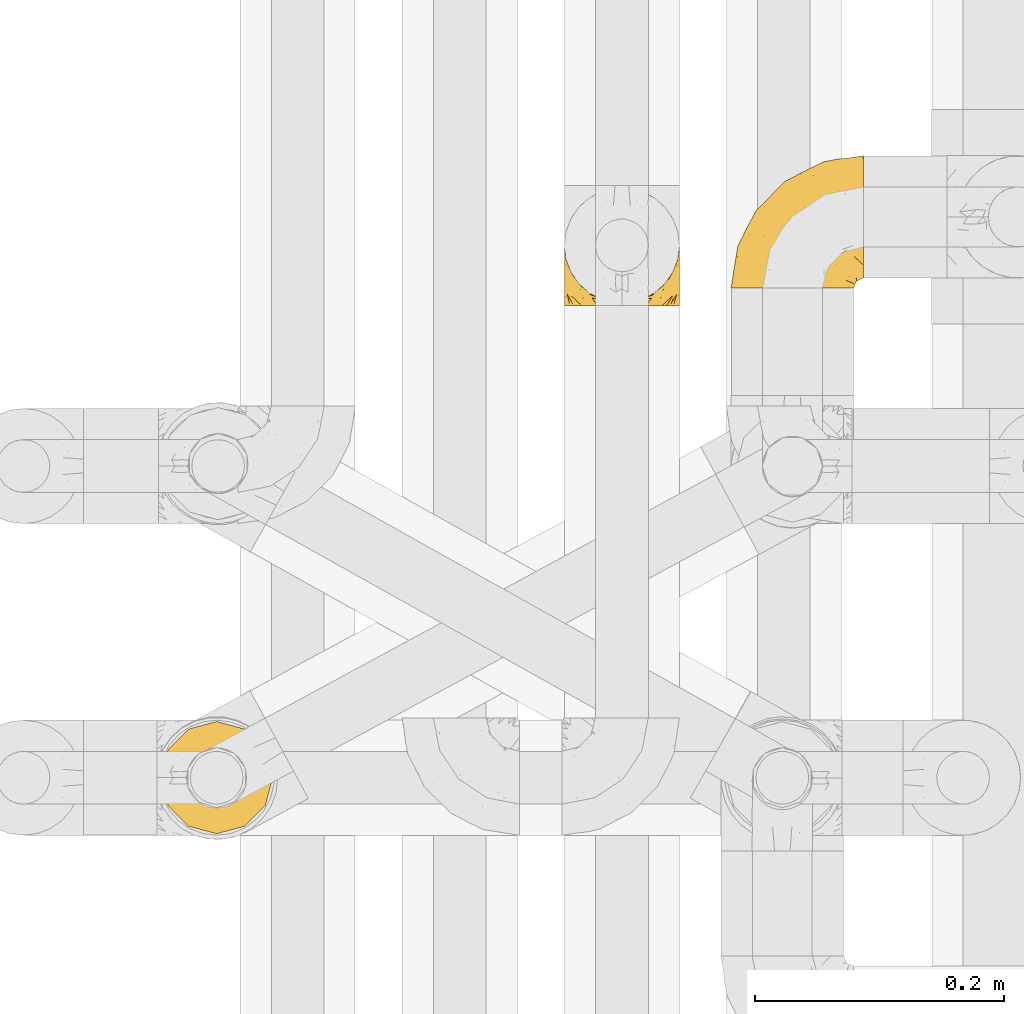
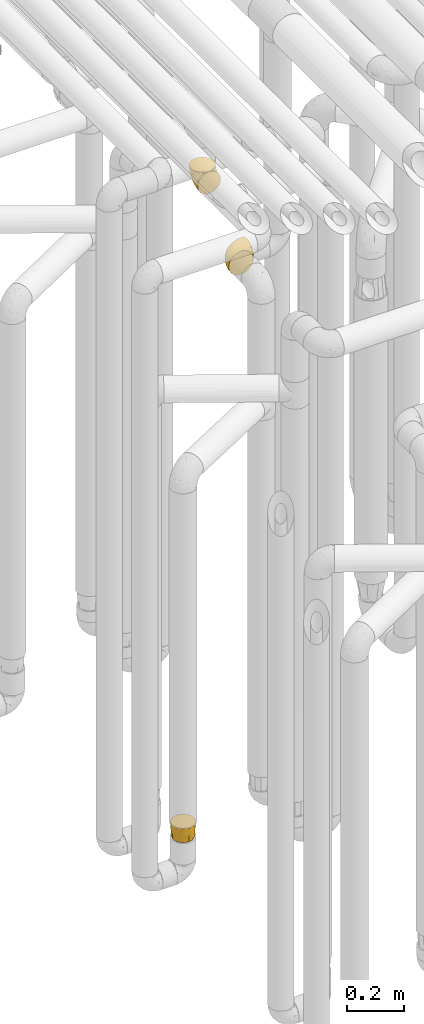
# One storey, part 160 of 827: 3 coverings.
"""IFC2X3 building model written with IfcOpenShell, lengths in millimetres."""

from ifc_helpers import new_model, entity, si_unit, converted_unit, derived_unit, direction, frame, origin, place, context, subcontext, project, spatial, faceted_brep, element, save


model = new_model("IFC2X3")

# Units and contexts
model_context = context("Model", 3, precision=0.01, world=origin(), true_north=direction((6.12303176911189e-17, 1.0)))
body_context = subcontext(model_context, "Body", "Model", "MODEL_VIEW")
ifc_project = project(units=[si_unit("LENGTHUNIT", "METRE", prefix="MILLI"), si_unit("AREAUNIT", "SQUARE_METRE"), si_unit("VOLUMEUNIT", "CUBIC_METRE"), converted_unit("PLANEANGLEUNIT", "DEGREE", entity("IfcRatioMeasure", 0.0174532925199433), si_unit("PLANEANGLEUNIT", "RADIAN"), dimensions=[0, 0, 0, 0, 0, 0, 0]), si_unit("MASSUNIT", "GRAM", prefix="KILO"), derived_unit("MASSDENSITYUNIT", [(si_unit("MASSUNIT", "GRAM", prefix="KILO"), 1), (si_unit("LENGTHUNIT", "METRE"), -3)]), derived_unit("MOMENTOFINERTIAUNIT", [(si_unit("LENGTHUNIT", "METRE"), 4)]), si_unit("TIMEUNIT", "SECOND"), si_unit("FREQUENCYUNIT", "HERTZ"), si_unit("THERMODYNAMICTEMPERATUREUNIT", "DEGREE_CELSIUS"), derived_unit("THERMALTRANSMITTANCEUNIT", [(si_unit("MASSUNIT", "GRAM", prefix="KILO"), 1), (si_unit("THERMODYNAMICTEMPERATUREUNIT", "KELVIN"), -1), (si_unit("TIMEUNIT", "SECOND"), -3)]), derived_unit("VOLUMETRICFLOWRATEUNIT", [(si_unit("LENGTHUNIT", "METRE"), 3), (si_unit("TIMEUNIT", "SECOND"), -1)]), derived_unit("MASSFLOWRATEUNIT", [(si_unit("MASSUNIT", "GRAM", prefix="KILO"), 1), (si_unit("TIMEUNIT", "SECOND"), -1)]), derived_unit("ROTATIONALFREQUENCYUNIT", [(si_unit("TIMEUNIT", "SECOND"), -1)]), si_unit("ELECTRICCURRENTUNIT", "AMPERE"), si_unit("ELECTRICVOLTAGEUNIT", "VOLT"), si_unit("POWERUNIT", "WATT"), si_unit("FORCEUNIT", "NEWTON", prefix="KILO"), si_unit("ILLUMINANCEUNIT", "LUX"), si_unit("LUMINOUSFLUXUNIT", "LUMEN"), si_unit("LUMINOUSINTENSITYUNIT", "CANDELA"), derived_unit("USERDEFINED", [(si_unit("MASSUNIT", "GRAM", prefix="KILO"), -1), (si_unit("LENGTHUNIT", "METRE"), -2), (si_unit("TIMEUNIT", "SECOND"), 3), (si_unit("LUMINOUSFLUXUNIT", "LUMEN"), 1)]), derived_unit("LINEARVELOCITYUNIT", [(si_unit("LENGTHUNIT", "METRE"), 1), (si_unit("TIMEUNIT", "SECOND"), -1)]), si_unit("PRESSUREUNIT", "PASCAL"), derived_unit("USERDEFINED", [(si_unit("LENGTHUNIT", "METRE"), -2), (si_unit("MASSUNIT", "GRAM", prefix="KILO"), 1), (si_unit("TIMEUNIT", "SECOND"), -2)]), derived_unit("LINEARFORCEUNIT", [(si_unit("MASSUNIT", "GRAM", prefix="KILO"), 1), (si_unit("LENGTHUNIT", "METRE"), 1), (si_unit("TIMEUNIT", "SECOND"), -2), (si_unit("LENGTHUNIT", "METRE"), -1)]), derived_unit("PLANARFORCEUNIT", [(si_unit("MASSUNIT", "GRAM", prefix="KILO"), 1), (si_unit("LENGTHUNIT", "METRE"), 1), (si_unit("TIMEUNIT", "SECOND"), -2), (si_unit("LENGTHUNIT", "METRE"), -2)])], contexts=[model_context])

# Site, building, storey
site_placement = place(None, origin())
site = spatial("IfcSite", under=ifc_project, at=site_placement, CompositionType="ELEMENT")
building_placement = place(site_placement, origin())
building = spatial("IfcBuilding", under=site, at=building_placement, CompositionType="ELEMENT")
storey_placement = place(building_placement, frame((0.0, 0.0, 28200.0)))
storey = spatial("IfcBuildingStorey", under=building, at=storey_placement, Name="08", CompositionType="ELEMENT", Elevation=28200.0)

# Coverings
covering_1_placement = place(storey_placement, frame((35686.11, 11947.49, 2549.25)))
element("IfcCovering", 1, at=covering_1_placement, inside=storey, Name=":ADSK_", ObjectType=":ADSK_", PredefinedType="INSULATION", context=body_context, shape_type="Brep", body=[
    faceted_brep([(50.75, 1.6, 99.9), (39.8, 1.6, 98.66), (29.41, 1.6, 95.02), (20.09, 1.6, 89.17), (12.31, 1.6, 81.38), (6.46, 1.6, 72.06), (2.83, 1.6, 61.68), (1.6, 1.6, 50.75), (2.83, 1.6, 39.8), (6.47, 1.6, 29.41), (12.32, 1.6, 20.09), (20.11, 1.6, 12.31), (29.43, 1.6, 6.46), (39.81, 1.6, 2.83), (50.75, 1.6, 1.6), (56.45, 1.6, 2.24), (61.69, 1.6, 2.83), (66.88, 1.6, 4.65), (72.08, 1.6, 6.47), (81.4, 1.6, 12.32), (89.18, 1.6, 20.11), (95.03, 1.6, 29.43), (98.66, 1.6, 39.81), (99.9, 1.6, 50.75), (98.66, 1.6, 61.69), (95.02, 1.6, 72.08), (89.17, 1.6, 81.4), (81.38, 1.6, 89.18), (72.06, 1.6, 95.03), (66.87, 1.6, 96.85), (61.68, 1.6, 98.66), (56.45, 1.6, 99.25), (53.6, 1.6, 99.57), (107.75, 11.12, 38.02), (107.75, 16.03, 26.17), (107.75, 19.94, 21.08), (107.75, 23.84, 15.99), (107.75, 28.93, 12.09), (107.75, 34.02, 8.18), (107.75, 39.95, 5.73), (107.75, 45.87, 3.27), (107.75, 52.86, 2.35), (107.75, 55.73, 1.97), (107.75, 58.6, 1.6), (107.75, 71.32, 3.27), (107.75, 83.17, 8.18), (107.75, 93.35, 15.99), (107.75, 101.16, 26.17), (107.75, 106.07, 38.02), (107.75, 107.75, 50.75), (107.75, 106.07, 63.47), (107.75, 101.16, 75.32), (107.75, 93.35, 85.5), (107.75, 83.17, 93.31), (107.75, 71.32, 98.22), (107.75, 58.6, 99.9), (107.75, 52.86, 99.14), (107.75, 45.87, 98.22), (107.75, 39.95, 95.77), (107.75, 34.02, 93.31), (107.75, 28.93, 89.4), (107.75, 23.84, 85.5), (107.75, 19.94, 80.41), (107.75, 16.03, 75.32), (107.75, 11.12, 63.47), (107.75, 9.45, 50.75), (39.38, 81.82, 59.31), (49.75, 84.02, 73.08), (57.38, 93.05, 63.72), (74.94, 102.55, 50.75), (85.97, 104.83, 58.64), (95.66, 105.83, 50.75), (67.82, 91.87, 76.74), (83.09, 101.74, 67.68), (89.16, 97.07, 78.92), (37.01, 38.45, 94.31), (43.46, 22.17, 98.76), (51.79, 42.04, 98.4), (85.58, 77.69, 94.57), (62.84, 75.76, 89.91), (62.77, 62.11, 96.32), (88.17, 66.08, 98.79), (85.93, 54.26, 99.9), (91.42, 55.35, 99.9), (96.91, 56.44, 99.9), (99.62, 56.98, 99.9), (102.33, 57.52, 99.9), (82.57, 87.84, 87.31), (32.75, 19.41, 95.61), (13.79, 48.89, 60.43), (6.77, 26.34, 65.24), (16.46, 44.55, 72.87), (55.08, 23.41, 99.9), (58.17, 28.03, 99.9), (61.26, 32.65, 99.9), (64.35, 37.28, 99.9), (67.44, 41.9, 99.9), (24.18, 20.6, 90.65), (23.37, 63.36, 63.14), (49.76, 62.21, 91.89), (9.84, 19.94, 75.25), (3.51, 13.68, 50.75), (55.75, 80.85, 82.18), (42.34, 66.53, 85.08), (37.78, 71.06, 76.93), (21.87, 63.99, 50.75), (33.61, 75.73, 50.75), (17.1, 26.77, 83.02), (51.28, 4.31, 99.9), (51.82, 7.01, 99.9), (52.9, 12.43, 99.9), (53.99, 17.92, 99.9), (28.01, 43.43, 87.13), (28.99, 56.23, 80.85), (69.9, 54.97, 99.17), (6.79, 34.4, 50.75), (72.06, 44.99, 99.9), (76.69, 48.08, 99.9), (81.31, 51.17, 99.9), (45.35, 87.47, 50.75), (34.79, 74.55, 67.61), (25.72, 60.86, 72.25), (14.33, 49.19, 50.75), (60.15, 95.01, 50.75), (62.38, 10.27, 98.69), (100.57, 48.79, 99.01), (91.06, 45.16, 98.79), (97.66, 44.99, 98.29), (97.55, 6.17, 68.51), (93.65, 7.65, 76.82), (66.85, 21.59, 98.54), (61.93, 19.96, 99.3), (101.4, 21.0, 83.57), (100.07, 27.2, 89.47), (101.36, 14.83, 75.76), (95.94, 19.7, 84.86), (96.3, 10.93, 75.89), (101.98, 9.63, 64.77), (85.88, 19.97, 90.83), (78.88, 21.13, 94.62), (82.8, 14.14, 90.37), (102.58, 30.2, 91.18), (82.88, 8.12, 88.65), (88.57, 9.93, 84.11), (88.67, 24.62, 91.75), (69.08, 11.87, 96.86), (102.19, 7.15, 50.75), (100.06, 5.32, 58.97), (70.56, 26.68, 98.37), (91.07, 13.92, 83.91), (77.56, 30.67, 97.52), (96.59, 36.65, 95.55), (86.38, 42.89, 98.76), (91.79, 34.04, 95.26), (81.71, 36.6, 98.04), (94.11, 26.41, 90.65), (76.09, 10.07, 93.51), (76.91, 15.83, 94.16), (81.44, 41.99, 99.1), (101.37, 14.83, 25.73), (94.12, 26.4, 10.84), (101.41, 21.01, 17.92), (95.96, 19.71, 16.64), (96.22, 5.72, 30.44), (66.85, 21.6, 2.95), (61.94, 19.96, 2.19), (58.17, 28.03, 1.6), (69.1, 11.87, 4.63), (88.58, 9.93, 17.39), (96.91, 56.44, 1.6), (102.33, 57.52, 1.6), (105.04, 58.06, 1.6), (82.9, 8.13, 12.86), (82.82, 14.15, 11.13), (97.66, 44.99, 3.2), (96.59, 36.65, 5.94), (100.07, 27.21, 12.02), (91.79, 34.04, 6.23), (102.58, 30.2, 10.31), (76.13, 10.06, 8.0), (76.93, 15.83, 7.34), (100.57, 48.79, 2.48), (86.38, 42.89, 2.73), (90.86, 45.38, 2.64), (52.9, 12.43, 1.6), (62.39, 10.28, 2.8), (101.98, 9.64, 36.71), (91.42, 55.35, 1.6), (85.93, 54.26, 1.6), (99.49, 6.05, 38.59), (51.82, 7.01, 1.6), (52.36, 9.72, 1.6), (61.26, 32.65, 1.6), (70.56, 26.68, 3.12), (91.09, 13.92, 17.59), (64.35, 37.28, 1.6), (77.6, 30.66, 3.98), (78.89, 21.14, 6.87), (81.71, 36.59, 3.45), (88.69, 24.6, 9.76), (53.99, 17.92, 1.6), (55.08, 23.41, 1.6), (96.31, 10.93, 25.62), (85.9, 19.97, 10.67), (81.45, 41.99, 2.39), (76.69, 48.08, 1.6), (81.31, 51.17, 1.6), (72.06, 44.99, 1.6), (67.44, 41.9, 1.6), (69.6, 55.26, 2.4), (85.97, 104.83, 42.85), (82.57, 87.84, 14.18), (63.16, 75.91, 11.56), (55.81, 80.84, 19.27), (67.81, 91.87, 24.75), (49.73, 83.98, 28.37), (32.55, 19.16, 5.95), (43.23, 22.37, 2.79), (88.17, 66.08, 2.71), (57.38, 93.05, 37.78), (83.08, 101.74, 33.81), (89.16, 97.07, 22.57), (85.58, 77.69, 6.92), (16.46, 44.55, 28.61), (6.77, 26.34, 36.24), (13.8, 48.9, 41.05), (37.71, 70.99, 24.55), (34.8, 74.55, 33.88), (36.83, 37.8, 7.11), (39.38, 81.82, 42.18), (17.12, 26.77, 18.46), (24.19, 20.6, 10.84), (28.89, 56.15, 20.69), (25.69, 60.85, 29.27), (51.77, 42.06, 3.1), (45.66, 57.03, 9.18), (23.39, 63.4, 38.38), (9.85, 19.94, 26.23), (28.11, 43.59, 14.34), (62.27, 62.61, 5.46), (42.35, 66.52, 16.39)], [[[0, 1, 2, 3, 4, 5, 6, 7, 8, 9, 10, 11, 12, 13, 14, 15, 16, 17, 18, 19, 20, 21, 22, 23, 24, 25, 26, 27, 28, 29, 30, 31, 32]], [[33, 34, 35, 36, 37, 38, 39, 40, 41, 42, 43, 44, 45, 46, 47, 48, 49, 50, 51, 52, 53, 54, 55, 56, 57, 58, 59, 60, 61, 62, 63, 64, 65]], [[66, 67, 68]], [[69, 70, 71]], [[68, 72, 73]], [[73, 72, 74]], [[75, 76, 77]], [[78, 79, 80]], [[51, 50, 73]], [[81, 82, 83, 84, 85, 86, 55]], [[52, 87, 53]], [[74, 52, 51]], [[2, 1, 88]], [[89, 90, 91]], [[77, 92, 93, 94, 95, 96]], [[55, 54, 81]], [[78, 53, 87]], [[5, 90, 6]], [[88, 76, 75]], [[97, 3, 2]], [[89, 91, 98]], [[99, 80, 79]], [[90, 5, 100]], [[74, 87, 52]], [[100, 5, 4]], [[90, 101, 6]], [[79, 102, 103]], [[102, 67, 104]], [[105, 98, 106]], [[107, 4, 3]], [[76, 0, 108, 109, 110, 111, 92]], [[107, 112, 113]], [[114, 77, 96]], [[89, 115, 90]], [[114, 96, 116, 117, 118, 82]], [[75, 97, 88]], [[119, 66, 68]], [[50, 71, 70]], [[100, 91, 90]], [[99, 77, 80]], [[102, 104, 103]], [[97, 107, 3]], [[80, 81, 78]], [[107, 97, 112]], [[68, 73, 70]], [[66, 98, 120]], [[78, 81, 54]], [[114, 81, 80]], [[53, 78, 54]], [[78, 87, 79]], [[102, 87, 72]], [[79, 103, 99]], [[4, 107, 100]], [[91, 100, 107]], [[88, 97, 2]], [[112, 97, 75]], [[99, 112, 75]], [[103, 104, 113]], [[91, 121, 98]], [[89, 105, 122, 115]], [[101, 90, 115]], [[101, 7, 6]], [[88, 1, 76]], [[0, 76, 1]], [[92, 77, 76]], [[73, 74, 51]], [[87, 74, 72]], [[81, 114, 82]], [[77, 114, 80]], [[87, 102, 79]], [[67, 102, 72]], [[68, 67, 72]], [[67, 120, 104]], [[120, 121, 104]], [[104, 121, 113]], [[121, 120, 98]], [[91, 107, 113]], [[91, 113, 121]], [[103, 113, 112]], [[106, 98, 66]], [[105, 89, 98]], [[106, 66, 119]], [[67, 66, 120]], [[68, 69, 123, 119]], [[50, 49, 71]], [[50, 70, 73]], [[112, 99, 103]], [[77, 99, 75]], [[69, 68, 70]], [[29, 124, 110]], [[84, 83, 125]], [[126, 82, 118]], [[59, 58, 127]], [[25, 128, 129]], [[130, 93, 131]], [[132, 62, 133]], [[134, 135, 136]], [[137, 65, 64]], [[64, 134, 137]], [[138, 139, 140]], [[111, 110, 124, 92]], [[134, 136, 137]], [[134, 64, 63]], [[141, 61, 60]], [[125, 58, 57]], [[142, 143, 140]], [[142, 26, 143]], [[127, 83, 82]], [[28, 124, 29]], [[108, 0, 32, 31, 30, 110, 109]], [[30, 29, 110]], [[135, 144, 138]], [[28, 145, 124]], [[57, 56, 55, 86, 85, 84]], [[146, 147, 23]], [[24, 23, 147]], [[25, 143, 26]], [[95, 94, 148]], [[24, 128, 25]], [[149, 138, 143]], [[124, 145, 131]], [[127, 58, 125]], [[150, 148, 139]], [[127, 126, 151]], [[151, 59, 127]], [[152, 151, 126]], [[153, 154, 155]], [[153, 133, 141]], [[145, 28, 27]], [[142, 156, 27]], [[157, 148, 130]], [[61, 133, 62]], [[134, 132, 135]], [[147, 128, 24]], [[65, 137, 146]], [[146, 137, 147]], [[128, 137, 136]], [[137, 128, 147]], [[128, 136, 129]], [[149, 129, 136]], [[25, 129, 143]], [[158, 152, 117]], [[152, 118, 117]], [[153, 151, 152]], [[158, 116, 154]], [[144, 150, 138]], [[153, 152, 158]], [[133, 153, 155]], [[133, 155, 132]], [[60, 151, 141]], [[135, 132, 155]], [[134, 63, 132]], [[144, 135, 155]], [[135, 138, 149]], [[155, 154, 144]], [[150, 154, 96]], [[154, 150, 144]], [[148, 94, 130]], [[82, 126, 127]], [[118, 152, 126]], [[150, 96, 95]], [[139, 148, 157]], [[150, 95, 148]], [[93, 92, 131]], [[130, 145, 156]], [[130, 94, 93]], [[84, 125, 57]], [[127, 125, 83]], [[140, 139, 157]], [[150, 139, 138]], [[140, 157, 142]], [[138, 140, 143]], [[156, 142, 157]], [[27, 26, 142]], [[130, 156, 157]], [[145, 27, 156]], [[132, 63, 62]], [[124, 131, 92]], [[130, 131, 145]], [[129, 149, 143]], [[135, 149, 136]], [[141, 133, 61]], [[60, 59, 151]], [[141, 151, 153]], [[116, 96, 154]], [[153, 158, 154]], [[158, 117, 116]], [[34, 33, 159]], [[160, 161, 162]], [[22, 21, 163]], [[164, 165, 166]], [[19, 18, 167]], [[168, 21, 20]], [[42, 41, 40, 169, 170, 171, 43]], [[172, 173, 168]], [[174, 38, 175]], [[176, 177, 178]], [[179, 164, 180]], [[40, 181, 169]], [[182, 183, 175]], [[17, 184, 185]], [[65, 146, 186]], [[187, 174, 188]], [[23, 22, 189]], [[174, 39, 38]], [[15, 14, 190, 191, 184, 16]], [[181, 40, 39]], [[192, 193, 164]], [[194, 163, 168]], [[33, 186, 159]], [[180, 173, 172]], [[195, 196, 193]], [[18, 185, 167]], [[173, 180, 197]], [[198, 199, 196]], [[200, 201, 185, 184]], [[184, 17, 16]], [[18, 17, 185]], [[202, 159, 186]], [[194, 168, 203]], [[189, 163, 202]], [[204, 205, 182]], [[187, 181, 174]], [[160, 177, 176]], [[206, 183, 182]], [[206, 182, 205]], [[201, 165, 185]], [[165, 164, 167]], [[172, 179, 180]], [[202, 194, 162]], [[176, 161, 160]], [[65, 186, 33]], [[163, 189, 22]], [[175, 177, 182]], [[174, 183, 188]], [[177, 198, 204]], [[199, 160, 162]], [[198, 207, 204]], [[175, 38, 37]], [[198, 177, 160]], [[178, 177, 175]], [[176, 35, 161]], [[34, 159, 161]], [[162, 161, 159]], [[202, 162, 159]], [[199, 162, 203]], [[196, 199, 203]], [[198, 160, 199]], [[193, 197, 180]], [[208, 198, 196]], [[188, 183, 206]], [[175, 183, 174]], [[193, 192, 195]], [[195, 208, 196]], [[197, 196, 203]], [[180, 164, 193]], [[168, 163, 21]], [[166, 165, 201]], [[166, 192, 164]], [[189, 202, 186]], [[186, 146, 189]], [[23, 189, 146]], [[174, 181, 39]], [[169, 181, 187]], [[196, 197, 193]], [[173, 203, 168]], [[203, 173, 197]], [[172, 168, 20]], [[20, 19, 172]], [[179, 172, 19]], [[19, 167, 179]], [[164, 179, 167]], [[35, 176, 36]], [[35, 34, 161]], [[185, 165, 167]], [[162, 194, 203]], [[163, 194, 202]], [[176, 178, 36]], [[37, 36, 178]], [[175, 37, 178]], [[177, 204, 182]], [[207, 198, 208]], [[207, 205, 204]], [[209, 188, 206, 205, 207, 208]], [[48, 210, 71]], [[211, 212, 213]], [[214, 213, 215]], [[216, 217, 13]], [[218, 43, 171, 170, 169, 187, 188]], [[219, 220, 214]], [[47, 46, 221]], [[210, 48, 220]], [[211, 222, 212]], [[222, 45, 44]], [[221, 220, 47]], [[47, 220, 48]], [[221, 211, 214]], [[223, 224, 225]], [[211, 46, 45]], [[226, 227, 215]], [[43, 218, 44]], [[217, 216, 228]], [[219, 215, 229]], [[14, 13, 217]], [[224, 9, 8]], [[10, 230, 11]], [[11, 231, 12]], [[232, 223, 233]], [[234, 208, 195, 192, 166, 201]], [[235, 234, 228]], [[222, 44, 218]], [[106, 229, 236]], [[224, 237, 9]], [[231, 238, 228]], [[9, 237, 10]], [[115, 224, 101]], [[239, 234, 235]], [[231, 11, 230]], [[223, 230, 237]], [[224, 8, 101]], [[223, 236, 233]], [[225, 115, 122, 105]], [[216, 12, 231]], [[209, 234, 239]], [[210, 219, 69]], [[219, 214, 215]], [[229, 119, 219]], [[209, 218, 188]], [[239, 212, 222]], [[239, 222, 218]], [[45, 222, 211]], [[235, 212, 239]], [[213, 212, 240]], [[223, 237, 224]], [[230, 10, 237]], [[238, 231, 230]], [[216, 231, 228]], [[232, 230, 223]], [[235, 238, 240]], [[115, 225, 224]], [[233, 236, 227]], [[8, 7, 101]], [[234, 209, 208]], [[218, 209, 239]], [[217, 228, 234]], [[13, 12, 216]], [[234, 201, 217]], [[217, 201, 200, 184, 191, 190, 14]], [[211, 221, 46]], [[220, 221, 214]], [[71, 210, 69]], [[71, 49, 48]], [[219, 210, 220]], [[226, 215, 213]], [[211, 213, 214]], [[226, 213, 240]], [[215, 227, 229]], [[232, 240, 238]], [[233, 227, 226]], [[232, 233, 226]], [[236, 223, 225]], [[240, 232, 226]], [[232, 238, 230]], [[225, 105, 236]], [[236, 105, 106]], [[236, 229, 227]], [[123, 69, 219, 119]], [[106, 119, 229]], [[238, 235, 228]], [[212, 235, 240]]]),
])
covering_2_placement = place(storey_placement, frame((35552.3, 11933.61, 2952.2)))
element("IfcCovering", 2, at=covering_2_placement, inside=storey, Name=":ADSK_", ObjectType=":ADSK_", PredefinedType="INSULATION", context=body_context, shape_type="Brep", body=[
    faceted_brep([(11.68, 1.6, 18.98), (19.0, 1.6, 11.67), (27.76, 1.6, 6.17), (37.52, 1.6, 2.75), (47.8, 1.6, 1.6), (58.08, 1.6, 2.75), (67.85, 1.6, 6.17), (76.61, 1.6, 11.68), (83.92, 1.6, 19.0), (89.42, 1.6, 27.76), (92.84, 1.6, 37.52), (94.0, 1.6, 47.8), (93.53, 1.6, 51.94), (93.18, 1.6, 55.01), (92.84, 1.6, 58.08), (91.13, 1.6, 62.96), (89.42, 1.6, 67.85), (86.66, 1.6, 72.23), (83.91, 1.6, 76.61), (80.25, 1.6, 80.26), (76.59, 1.6, 83.92), (67.83, 1.6, 89.42), (62.95, 1.6, 91.13), (58.07, 1.6, 92.84), (47.8, 1.6, 94.0), (37.51, 1.6, 92.84), (32.63, 1.6, 91.13), (27.74, 1.6, 89.42), (18.98, 1.6, 83.91), (15.33, 1.6, 80.25), (11.67, 1.6, 76.59), (8.92, 1.6, 72.21), (6.17, 1.6, 67.83), (4.46, 1.6, 62.95), (2.75, 1.6, 58.07), (2.41, 1.6, 55.0), (2.06, 1.6, 51.94), (1.6, 1.6, 47.8), (2.75, 1.6, 37.51), (6.17, 1.6, 27.74), (47.8, 3.4, 95.8), (59.75, 4.97, 95.8), (70.9, 9.58, 95.8), (75.68, 13.26, 95.8), (80.46, 16.93, 95.8), (84.13, 21.71, 95.8), (87.81, 26.5, 95.8), (90.11, 32.07, 95.8), (92.42, 37.64, 95.8), (92.9, 41.25, 95.8), (93.17, 43.34, 95.8), (93.45, 45.42, 95.8), (94.0, 49.6, 95.8), (92.42, 61.55, 95.8), (87.81, 72.7, 95.8), (80.46, 82.26, 95.8), (70.9, 89.61, 95.8), (59.75, 94.22, 95.8), (47.8, 95.8, 95.8), (35.84, 94.22, 95.8), (24.7, 89.61, 95.8), (15.13, 82.26, 95.8), (7.78, 72.7, 95.8), (3.17, 61.55, 95.8), (1.6, 49.6, 95.8), (2.14, 45.42, 95.8), (2.69, 41.25, 95.8), (3.17, 37.64, 95.8), (5.48, 32.07, 95.8), (7.78, 26.5, 95.8), (11.46, 21.71, 95.8), (15.13, 16.93, 95.8), (19.91, 13.26, 95.8), (24.7, 9.58, 95.8), (35.84, 4.97, 95.8), (23.61, 81.55, 60.58), (31.99, 90.4, 74.11), (35.87, 83.0, 51.59), (47.8, 91.18, 66.69), (40.43, 93.13, 76.19), (47.8, 94.0, 84.43), (31.83, 66.19, 31.2), (23.37, 70.92, 42.88), (21.41, 85.95, 79.41), (3.07, 49.74, 60.7), (1.6, 35.54, 61.85), (1.6, 38.14, 65.75), (1.6, 40.74, 69.64), (1.6, 43.34, 73.53), (1.6, 45.94, 77.43), (13.45, 77.59, 74.59), (15.25, 71.17, 54.72), (8.07, 65.81, 64.18), (16.0, 59.03, 37.94), (17.34, 45.85, 25.89), (10.58, 45.79, 34.73), (5.34, 41.42, 42.89), (2.39, 34.51, 49.83), (8.36, 56.04, 48.58), (10.04, 15.15, 22.41), (2.59, 56.51, 78.69), (6.28, 68.39, 81.64), (34.28, 23.33, 6.22), (38.73, 42.86, 12.11), (27.25, 39.42, 14.81), (29.88, 53.58, 21.61), (38.6, 59.17, 22.41), (23.44, 59.06, 30.12), (25.25, 22.63, 10.01), (17.23, 20.55, 15.36), (47.8, 12.96, 3.39), (47.8, 56.96, 19.59), (47.8, 67.38, 30.01), (2.53, 18.72, 41.19), (1.6, 5.33, 48.54), (1.6, 9.07, 49.28), (1.6, 11.79, 49.82), (1.6, 14.51, 50.37), (1.6, 17.24, 50.91), (1.6, 19.96, 51.45), (5.71, 21.03, 31.61), (1.6, 46.48, 80.15), (1.6, 47.03, 82.88), (1.6, 47.57, 85.6), (1.6, 48.11, 88.32), (1.6, 48.48, 90.19), (1.6, 48.85, 92.06), (47.8, 30.7, 6.21), (1.6, 23.86, 54.05), (1.6, 27.75, 56.65), (1.6, 31.64, 59.25), (11.89, 31.26, 24.66), (47.8, 77.8, 40.43), (39.69, 72.75, 35.17), (47.8, 43.83, 12.9), (47.8, 84.49, 53.56), (13.84, 14.58, 85.34), (9.16, 16.17, 78.44), (15.79, 10.82, 84.37), (25.75, 4.64, 89.05), (16.09, 7.71, 82.76), (7.51, 25.13, 86.31), (3.99, 32.66, 83.73), (2.66, 34.94, 77.31), (3.16, 36.76, 87.78), (2.35, 40.48, 87.91), (2.23, 39.25, 81.29), (38.35, 3.69, 93.97), (6.18, 13.99, 70.76), (2.7, 21.85, 63.67), (2.93, 17.93, 62.62), (16.01, 15.11, 90.64), (9.08, 21.14, 84.08), (11.68, 7.21, 77.45), (6.83, 9.47, 70.34), (4.65, 32.27, 88.72), (3.65, 25.68, 71.28), (3.61, 22.18, 68.09), (12.8, 18.79, 91.07), (2.43, 10.12, 57.47), (21.65, 10.45, 91.35), (3.7, 11.29, 62.99), (47.8, 2.87, 94.52), (3.37, 31.16, 76.47), (9.3, 12.7, 76.28), (7.03, 6.31, 69.96), (7.87, 25.62, 89.86), (7.26, 21.18, 78.94), (3.41, 28.81, 73.51), (23.81, 7.45, 89.62), (86.5, 21.14, 84.09), (88.08, 25.13, 86.3), (82.79, 18.79, 91.06), (94.0, 48.85, 92.06), (94.0, 47.03, 82.88), (94.0, 47.57, 85.6), (94.0, 48.11, 88.32), (57.24, 3.69, 93.97), (71.76, 7.44, 89.63), (94.0, 14.51, 50.37), (94.0, 11.79, 49.82), (94.0, 5.33, 48.54), (94.0, 9.07, 49.28), (79.49, 7.71, 82.77), (88.75, 9.47, 70.36), (92.93, 34.94, 77.31), (92.22, 31.16, 76.47), (94.0, 40.74, 69.64), (94.0, 38.14, 65.75), (92.43, 36.76, 87.78), (93.24, 40.48, 87.91), (69.82, 4.63, 89.06), (79.57, 15.11, 90.65), (81.74, 14.58, 85.35), (94.0, 43.34, 73.53), (94.0, 45.94, 77.43), (93.36, 39.25, 81.29), (83.9, 7.21, 77.46), (86.28, 12.69, 76.29), (93.16, 10.14, 57.47), (92.88, 21.81, 63.71), (91.98, 22.19, 68.11), (89.41, 14.0, 70.77), (91.93, 25.69, 71.31), (86.42, 16.17, 78.46), (88.82, 6.66, 69.52), (92.66, 17.92, 62.64), (73.93, 10.45, 91.35), (94.0, 31.64, 59.25), (79.5, 10.64, 84.6), (91.89, 11.31, 62.98), (94.0, 19.96, 51.45), (94.0, 23.86, 54.05), (94.0, 27.75, 56.65), (91.6, 32.66, 83.73), (94.0, 46.48, 80.15), (90.94, 32.27, 88.72), (94.0, 35.54, 61.85), (92.16, 28.77, 73.56), (88.32, 21.17, 78.96), (86.13, 23.36, 91.36), (94.0, 17.24, 50.91), (93.2, 47.58, 62.87), (55.16, 93.13, 76.19), (82.02, 77.44, 73.57), (84.29, 66.78, 56.07), (76.94, 71.68, 49.77), (68.33, 74.96, 44.73), (71.98, 81.55, 60.58), (92.52, 36.7, 47.64), (92.9, 56.9, 78.32), (59.72, 83.0, 51.59), (63.6, 90.4, 74.11), (88.89, 67.83, 76.04), (74.18, 85.95, 79.41), (68.35, 39.41, 14.82), (61.33, 23.33, 6.22), (56.86, 42.87, 12.12), (68.62, 53.92, 23.51), (63.76, 66.19, 31.2), (72.19, 64.12, 34.96), (88.69, 33.13, 33.86), (92.19, 23.1, 38.94), (89.75, 16.98, 30.23), (55.9, 72.75, 35.17), (77.99, 23.77, 15.85), (85.21, 18.41, 22.59), (74.99, 43.7, 21.56), (90.23, 54.53, 55.94), (59.86, 55.72, 20.67), (70.75, 17.73, 9.19), (81.72, 38.98, 25.79), (86.53, 50.28, 41.16), (79.6, 59.02, 37.95)], [[[0, 1, 2, 3, 4, 5, 6, 7, 8, 9, 10, 11, 12, 13, 14, 15, 16, 17, 18, 19, 20, 21, 22, 23, 24, 25, 26, 27, 28, 29, 30, 31, 32, 33, 34, 35, 36, 37, 38, 39]], [[40, 41, 42, 43, 44, 45, 46, 47, 48, 49, 50, 51, 52, 53, 54, 55, 56, 57, 58, 59, 60, 61, 62, 63, 64, 65, 66, 67, 68, 69, 70, 71, 72, 73, 74]], [[75, 76, 77]], [[78, 79, 80]], [[77, 81, 82]], [[76, 75, 83]], [[84, 85, 86, 87, 88, 89]], [[90, 91, 92]], [[76, 60, 59]], [[93, 94, 95]], [[90, 62, 61]], [[83, 61, 60]], [[96, 97, 84]], [[98, 93, 95]], [[0, 39, 99]], [[100, 84, 89]], [[62, 101, 63]], [[2, 102, 3]], [[92, 84, 100]], [[103, 102, 104]], [[103, 105, 106]], [[93, 107, 94]], [[1, 108, 2]], [[92, 101, 90]], [[108, 1, 109]], [[102, 110, 3]], [[93, 82, 107]], [[102, 108, 104]], [[111, 106, 112]], [[109, 0, 99]], [[113, 37, 114, 115, 116, 117, 118, 119]], [[120, 38, 113]], [[100, 89, 121, 122, 123, 124, 125, 126, 64]], [[127, 102, 103]], [[97, 119, 128, 129, 130, 85]], [[99, 120, 131]], [[132, 133, 77]], [[59, 80, 79]], [[1, 0, 109]], [[98, 84, 92]], [[94, 109, 131]], [[120, 39, 38]], [[93, 91, 82]], [[104, 94, 105]], [[97, 113, 119]], [[95, 120, 96]], [[83, 90, 61]], [[91, 93, 98]], [[64, 63, 100]], [[100, 63, 101]], [[77, 76, 79]], [[133, 106, 81]], [[84, 97, 85]], [[113, 96, 120]], [[113, 97, 96]], [[37, 113, 38]], [[110, 102, 127]], [[110, 4, 3]], [[103, 111, 134, 127]], [[90, 75, 91]], [[82, 81, 107]], [[91, 75, 82]], [[77, 82, 75]], [[76, 83, 60]], [[90, 83, 75]], [[105, 107, 81]], [[94, 131, 95]], [[105, 94, 107]], [[109, 94, 104]], [[120, 95, 131]], [[98, 95, 96]], [[84, 98, 96]], [[98, 92, 91]], [[106, 105, 81]], [[103, 104, 105]], [[112, 106, 133]], [[103, 106, 111]], [[112, 133, 132]], [[81, 77, 133]], [[77, 78, 135, 132]], [[120, 99, 39]], [[109, 99, 131]], [[59, 58, 80]], [[59, 79, 76]], [[90, 101, 62]], [[100, 101, 92]], [[2, 108, 102]], [[109, 104, 108]], [[78, 77, 79]], [[136, 137, 138]], [[27, 139, 140]], [[141, 142, 143]], [[144, 145, 121]], [[146, 89, 88]], [[147, 139, 25]], [[148, 149, 150]], [[136, 151, 152]], [[147, 40, 74]], [[24, 147, 25]], [[153, 148, 154]], [[33, 116, 34]], [[73, 72, 151]], [[114, 37, 36, 35, 34, 116, 115]], [[146, 155, 144]], [[156, 85, 130]], [[157, 149, 148]], [[151, 158, 152]], [[117, 33, 159]], [[29, 153, 154]], [[160, 74, 73]], [[161, 128, 119]], [[65, 64, 126, 125, 124, 123, 122, 67, 66]], [[162, 147, 24]], [[27, 140, 28]], [[149, 129, 150]], [[139, 27, 26, 25]], [[68, 144, 69]], [[129, 128, 150]], [[163, 87, 86]], [[130, 129, 149]], [[122, 145, 67]], [[153, 164, 148]], [[161, 119, 159]], [[165, 30, 154]], [[150, 154, 148]], [[128, 161, 150]], [[30, 165, 31]], [[145, 144, 68]], [[89, 146, 144]], [[87, 163, 143]], [[166, 155, 142]], [[88, 87, 143]], [[161, 154, 150]], [[154, 30, 29]], [[29, 28, 153]], [[28, 140, 153]], [[164, 153, 140]], [[140, 137, 164]], [[157, 148, 164]], [[156, 130, 157]], [[164, 137, 157]], [[157, 137, 156]], [[167, 137, 136]], [[168, 85, 156]], [[152, 168, 167]], [[167, 168, 156]], [[163, 152, 141]], [[71, 158, 72]], [[152, 167, 136]], [[88, 142, 146]], [[144, 155, 69]], [[146, 142, 155]], [[70, 166, 71]], [[142, 141, 166]], [[70, 69, 155]], [[141, 158, 71]], [[160, 73, 151]], [[138, 137, 140]], [[160, 136, 169]], [[136, 160, 151]], [[74, 160, 169]], [[152, 158, 141]], [[151, 72, 158]], [[168, 152, 163]], [[137, 167, 156]], [[163, 86, 168]], [[85, 168, 86]], [[116, 33, 117]], [[130, 149, 157]], [[67, 145, 68]], [[121, 89, 144]], [[145, 122, 121]], [[40, 147, 162]], [[169, 147, 74]], [[159, 33, 32]], [[161, 159, 32]], [[159, 119, 118, 117]], [[139, 147, 169]], [[139, 169, 138]], [[161, 32, 31]], [[141, 143, 163]], [[88, 143, 142]], [[71, 166, 141]], [[155, 166, 70]], [[139, 138, 140]], [[169, 136, 138]], [[154, 161, 165]], [[161, 31, 165]], [[170, 171, 172]], [[173, 52, 51, 50, 49, 48, 174, 175, 176]], [[177, 178, 41]], [[179, 15, 180]], [[12, 11, 181, 182, 180, 14, 13]], [[183, 21, 20]], [[19, 18, 184]], [[185, 186, 187]], [[186, 188, 187]], [[43, 172, 44]], [[189, 190, 47]], [[23, 22, 21, 191]], [[170, 192, 193]], [[40, 162, 177]], [[194, 195, 196]], [[24, 23, 177]], [[197, 198, 183]], [[199, 15, 179]], [[47, 46, 189]], [[200, 201, 202]], [[201, 203, 204]], [[205, 206, 184]], [[207, 41, 178]], [[16, 15, 199]], [[14, 180, 15]], [[202, 201, 198]], [[208, 201, 200]], [[162, 24, 177]], [[48, 47, 190]], [[196, 195, 189]], [[197, 184, 202]], [[204, 193, 209]], [[210, 211, 212]], [[206, 212, 213]], [[205, 17, 210]], [[184, 206, 202]], [[210, 212, 206]], [[185, 194, 214]], [[189, 215, 190]], [[216, 45, 214]], [[186, 171, 170]], [[189, 216, 196]], [[197, 20, 19]], [[194, 185, 187]], [[197, 183, 20]], [[184, 197, 19]], [[197, 202, 198]], [[206, 200, 202]], [[204, 183, 198]], [[201, 208, 203]], [[203, 208, 217]], [[204, 198, 201]], [[217, 188, 218]], [[193, 219, 170]], [[171, 186, 185]], [[170, 218, 186]], [[170, 219, 218]], [[42, 207, 192]], [[171, 220, 172]], [[216, 189, 46]], [[214, 194, 196]], [[44, 220, 45]], [[214, 196, 216]], [[216, 46, 45]], [[214, 45, 220]], [[192, 43, 42]], [[204, 203, 219]], [[207, 193, 192]], [[209, 193, 178]], [[41, 207, 42]], [[193, 207, 178]], [[43, 192, 172]], [[170, 172, 192]], [[204, 219, 193]], [[219, 203, 218]], [[217, 218, 203]], [[188, 186, 218]], [[206, 213, 200]], [[208, 200, 213]], [[199, 210, 16]], [[215, 189, 195]], [[215, 174, 190]], [[174, 48, 190]], [[199, 179, 221, 211]], [[210, 199, 211]], [[23, 191, 177]], [[40, 177, 41]], [[183, 209, 191]], [[183, 191, 21]], [[191, 178, 177]], [[205, 18, 17]], [[17, 16, 210]], [[171, 185, 214]], [[172, 220, 44]], [[214, 220, 171]], [[191, 209, 178]], [[204, 209, 183]], [[206, 205, 210]], [[18, 205, 184]], [[222, 195, 194, 187, 188, 217]], [[57, 223, 80]], [[224, 225, 226]], [[226, 227, 228]], [[229, 217, 208, 213, 212, 211]], [[230, 52, 173, 176, 175, 174, 215, 195]], [[231, 232, 228]], [[231, 78, 223]], [[223, 57, 232]], [[224, 233, 225]], [[233, 54, 53]], [[234, 232, 56]], [[56, 55, 234]], [[234, 224, 228]], [[235, 236, 237]], [[224, 55, 54]], [[238, 239, 240]], [[52, 230, 53]], [[241, 242, 243]], [[231, 227, 244]], [[11, 10, 242]], [[236, 6, 5]], [[7, 245, 8]], [[8, 246, 9]], [[238, 247, 235]], [[222, 229, 248]], [[242, 211, 221, 179, 180, 182, 181, 11]], [[233, 53, 230]], [[111, 112, 249]], [[250, 6, 236]], [[246, 251, 241]], [[6, 250, 7]], [[127, 236, 110]], [[248, 229, 252]], [[246, 8, 245]], [[235, 245, 250]], [[236, 5, 110]], [[235, 249, 238]], [[237, 236, 127]], [[243, 9, 246]], [[252, 229, 241]], [[56, 232, 57]], [[222, 230, 195]], [[225, 248, 252]], [[248, 233, 230]], [[54, 233, 224]], [[231, 228, 227]], [[244, 132, 231]], [[248, 225, 233]], [[226, 225, 253]], [[235, 250, 236]], [[245, 7, 250]], [[251, 246, 245]], [[243, 246, 241]], [[247, 245, 235]], [[252, 251, 253]], [[229, 222, 217]], [[230, 222, 248]], [[5, 4, 110]], [[237, 127, 134, 111]], [[238, 249, 239]], [[224, 234, 55]], [[232, 234, 228]], [[242, 241, 229]], [[10, 9, 243]], [[211, 242, 229]], [[10, 243, 242]], [[80, 223, 78]], [[80, 58, 57]], [[231, 223, 232]], [[227, 240, 239]], [[224, 226, 228]], [[240, 226, 253]], [[227, 239, 244]], [[226, 240, 227]], [[251, 247, 253]], [[240, 253, 247]], [[249, 235, 237]], [[237, 111, 249]], [[244, 239, 249]], [[112, 244, 249]], [[135, 78, 231, 132]], [[112, 132, 244]], [[247, 238, 240]], [[245, 247, 251]], [[251, 252, 241]], [[225, 252, 253]]]),
])
covering_3_placement = place(storey_placement, frame((35228.44, 11509.67, 540.0)))
element("IfcCovering", 3, at=covering_3_placement, inside=storey, Name=":ADSK_", ObjectType=":ADSK_", PredefinedType="INSULATION", context=body_context, shape_type="Brep", body=[
    faceted_brep([(15.86, 15.86, 64.0), (24.1, 7.62, 64.0), (35.35, 4.61, 64.0), (46.6, 1.6, 64.0), (57.85, 4.61, 64.0), (69.1, 7.62, 64.0), (77.33, 15.86, 64.0), (85.57, 24.1, 64.0), (88.58, 35.35, 64.0), (91.6, 46.6, 64.0), (88.58, 57.85, 64.0), (85.57, 69.1, 64.0), (77.33, 77.33, 64.0), (69.1, 85.57, 64.0), (57.85, 88.58, 64.0), (46.6, 91.6, 64.0), (35.35, 88.58, 64.0), (24.1, 85.57, 64.0), (15.86, 77.33, 64.0), (7.62, 69.1, 64.0), (4.61, 57.85, 64.0), (1.6, 46.6, 64.0), (4.61, 35.35, 64.0), (7.62, 24.1, 64.0), (11.09, 67.04, 0.0), (18.59, 74.54, 0.0), (26.1, 82.04, 0.0), (38.8, 85.45, 0.0), (46.6, 87.54, 0.0), (56.85, 84.79, 0.0), (67.1, 82.04, 0.0), (74.6, 74.54, 0.0), (82.1, 67.04, 0.0), (85.51, 54.33, 0.0), (87.6, 46.54, 0.0), (84.85, 36.29, 0.0), (82.1, 26.04, 0.0), (74.6, 18.53, 0.0), (67.1, 11.03, 0.0), (54.39, 7.62, 0.0), (46.6, 5.54, 0.0), (36.35, 8.28, 0.0), (26.1, 11.03, 0.0), (18.59, 18.53, 0.0), (11.09, 26.04, 0.0), (7.68, 38.74, 0.0), (5.6, 46.54, 0.0), (8.34, 56.79, 0.0), (63.05, 6.84, 32.0), (55.0, 4.31, 33.43), (46.6, 3.51, 32.84), (70.94, 11.12, 32.0), (88.25, 35.88, 32.0), (80.71, 20.39, 32.0), (85.4, 28.04, 32.0), (89.65, 46.57, 32.84), (86.32, 63.02, 32.0), (88.86, 54.98, 33.43), (82.04, 70.91, 32.0), (57.28, 88.22, 32.0), (72.77, 80.68, 32.0), (65.12, 85.37, 32.0), (46.6, 89.62, 32.84), (30.14, 86.29, 32.0), (38.19, 88.83, 33.43), (22.25, 82.01, 32.0), (4.94, 57.25, 32.0), (12.48, 72.74, 32.0), (7.79, 65.09, 32.0), (3.54, 46.57, 32.84), (6.87, 30.11, 32.0), (4.33, 38.16, 33.43), (11.15, 22.22, 32.0), (35.91, 4.91, 32.0), (20.42, 12.45, 32.0), (28.07, 7.76, 32.0)], [[[0, 1, 2, 3, 4, 5, 6, 7, 8, 9, 10, 11, 12, 13, 14, 15, 16, 17, 18, 19, 20, 21, 22, 23]], [[24, 25, 26, 27, 28, 29, 30, 31, 32, 33, 34, 35, 36, 37, 38, 39, 40, 41, 42, 43, 44, 45, 46, 47]], [[39, 48, 49]], [[39, 50, 40]], [[48, 39, 38]], [[5, 4, 48]], [[51, 5, 48]], [[48, 4, 49]], [[9, 8, 52]], [[53, 51, 37]], [[51, 48, 38]], [[7, 53, 54]], [[54, 53, 36]], [[37, 36, 53]], [[51, 38, 37]], [[50, 49, 3]], [[53, 6, 51]], [[6, 5, 51]], [[6, 53, 7]], [[52, 8, 54]], [[54, 35, 52]], [[54, 36, 35]], [[3, 49, 4]], [[8, 7, 54]], [[34, 55, 9, 52]], [[39, 49, 50]], [[34, 52, 35]], [[33, 56, 57]], [[33, 55, 34]], [[56, 33, 32]], [[11, 10, 56]], [[58, 11, 56]], [[56, 10, 57]], [[15, 14, 59]], [[60, 58, 31]], [[58, 56, 32]], [[13, 60, 61]], [[61, 60, 30]], [[31, 30, 60]], [[58, 32, 31]], [[55, 57, 9]], [[60, 12, 58]], [[12, 11, 58]], [[12, 60, 13]], [[59, 14, 61]], [[61, 29, 59]], [[61, 30, 29]], [[9, 57, 10]], [[14, 13, 61]], [[28, 62, 15, 59]], [[33, 57, 55]], [[28, 59, 29]], [[27, 63, 64]], [[27, 62, 28]], [[63, 27, 26]], [[17, 16, 63]], [[65, 17, 63]], [[63, 16, 64]], [[21, 20, 66]], [[67, 65, 25]], [[65, 63, 26]], [[19, 67, 68]], [[68, 67, 24]], [[25, 24, 67]], [[65, 26, 25]], [[62, 64, 15]], [[67, 18, 65]], [[18, 17, 65]], [[18, 67, 19]], [[66, 20, 68]], [[68, 47, 66]], [[68, 24, 47]], [[15, 64, 16]], [[20, 19, 68]], [[46, 69, 21, 66]], [[27, 64, 62]], [[46, 66, 47]], [[45, 70, 71]], [[45, 69, 46]], [[70, 45, 44]], [[23, 22, 70]], [[72, 23, 70]], [[70, 22, 71]], [[3, 2, 73]], [[74, 72, 43]], [[72, 70, 44]], [[1, 74, 75]], [[75, 74, 42]], [[43, 42, 74]], [[72, 44, 43]], [[69, 71, 21]], [[74, 0, 72]], [[0, 23, 72]], [[0, 74, 1]], [[73, 2, 75]], [[75, 41, 73]], [[75, 42, 41]], [[21, 71, 22]], [[2, 1, 75]], [[40, 50, 3, 73]], [[45, 71, 69]], [[40, 73, 41]]]),
])

save(model, "model.ifc")
